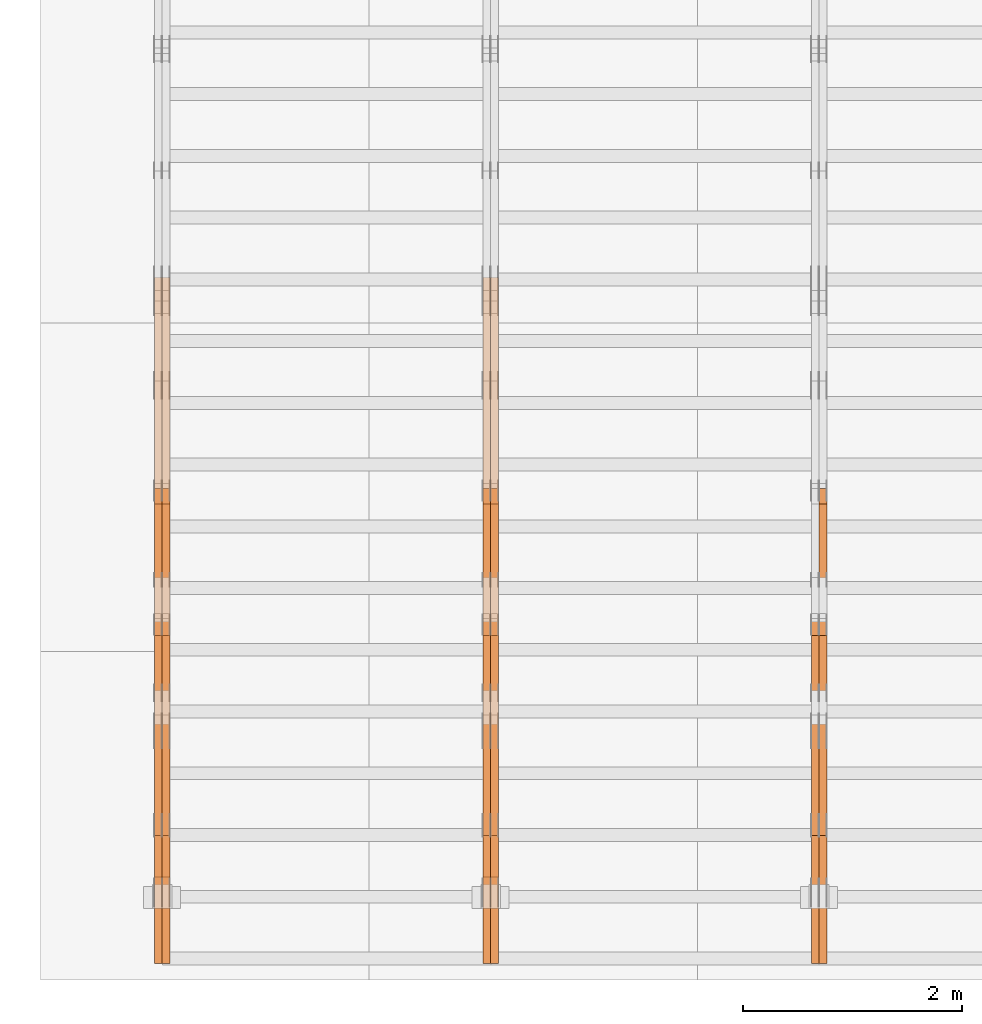
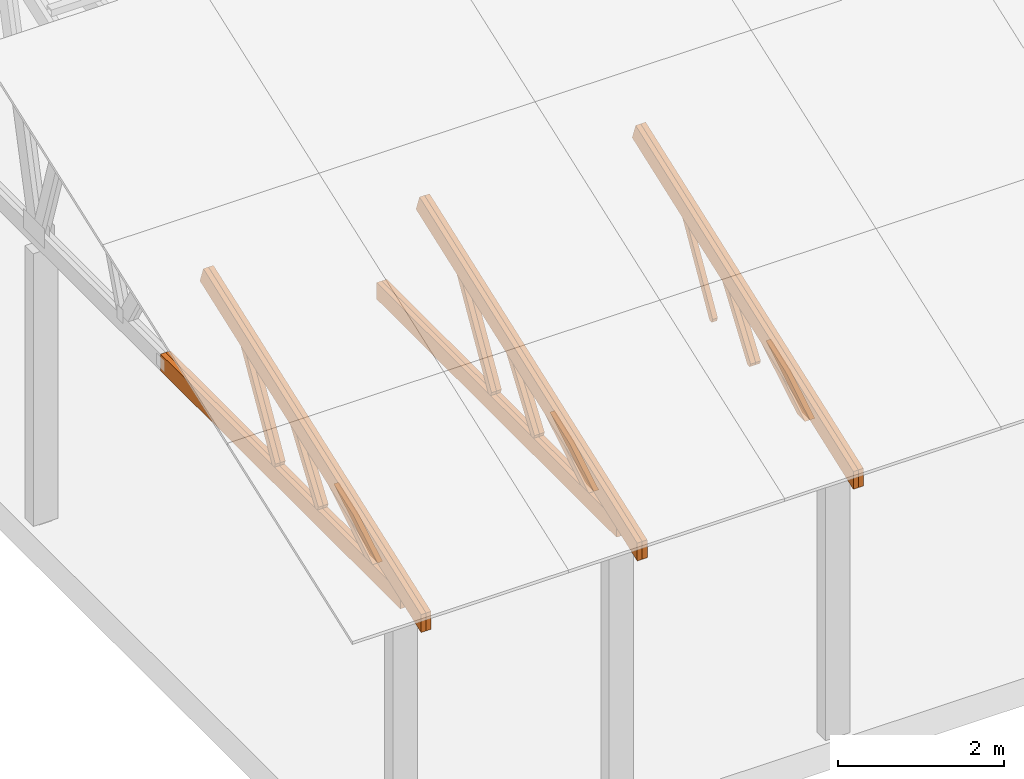
# One storey, part 12 of 189: 27 proxies.
"""IFC2X3 building model written with IfcOpenShell, lengths in millimetres."""

from ifc_helpers import new_model, entity, si_unit, converted_unit, derived_unit, direction, frame, origin, place, context, subcontext, project, spatial, polyline, outline, extrude, source, transform, mapped, material, type_object, type_shapes, element, save


model = new_model("IFC2X3")

# Units and contexts
model_context = context("Model", 3, precision=0.01, world=origin(), true_north=direction((6.12303176911189e-17, 1.0)))
body_context = subcontext(model_context, "Body", "Model", "MODEL_VIEW")
ifc_project = project(units=[si_unit("LENGTHUNIT", "METRE", prefix="MILLI"), si_unit("AREAUNIT", "SQUARE_METRE"), si_unit("VOLUMEUNIT", "CUBIC_METRE"), converted_unit("PLANEANGLEUNIT", "DEGREE", entity("IfcRatioMeasure", 0.0174532925199433), si_unit("PLANEANGLEUNIT", "RADIAN"), dimensions=[0, 0, 0, 0, 0, 0, 0]), si_unit("MASSUNIT", "GRAM", prefix="KILO"), derived_unit("MASSDENSITYUNIT", [(si_unit("MASSUNIT", "GRAM", prefix="KILO"), 1), (si_unit("LENGTHUNIT", "METRE"), -3)]), si_unit("TIMEUNIT", "SECOND"), si_unit("FREQUENCYUNIT", "HERTZ"), si_unit("THERMODYNAMICTEMPERATUREUNIT", "DEGREE_CELSIUS"), derived_unit("THERMALTRANSMITTANCEUNIT", [(si_unit("MASSUNIT", "GRAM", prefix="KILO"), 1), (si_unit("THERMODYNAMICTEMPERATUREUNIT", "KELVIN"), -1), (si_unit("TIMEUNIT", "SECOND"), -3)]), derived_unit("VOLUMETRICFLOWRATEUNIT", [(si_unit("LENGTHUNIT", "METRE"), 3), (si_unit("TIMEUNIT", "SECOND"), -1)]), si_unit("ELECTRICCURRENTUNIT", "AMPERE"), si_unit("ELECTRICVOLTAGEUNIT", "VOLT"), si_unit("POWERUNIT", "WATT"), si_unit("FORCEUNIT", "NEWTON"), si_unit("ILLUMINANCEUNIT", "LUX"), si_unit("LUMINOUSFLUXUNIT", "LUMEN"), si_unit("LUMINOUSINTENSITYUNIT", "CANDELA"), derived_unit("USERDEFINED", [(si_unit("MASSUNIT", "GRAM", prefix="KILO"), -1), (si_unit("LENGTHUNIT", "METRE"), -2), (si_unit("TIMEUNIT", "SECOND"), 3), (si_unit("LUMINOUSFLUXUNIT", "LUMEN"), 1)]), derived_unit("LINEARVELOCITYUNIT", [(si_unit("LENGTHUNIT", "METRE"), 1), (si_unit("TIMEUNIT", "SECOND"), -1)]), si_unit("PRESSUREUNIT", "PASCAL"), derived_unit("USERDEFINED", [(si_unit("LENGTHUNIT", "METRE"), -2), (si_unit("MASSUNIT", "GRAM", prefix="KILO"), 1), (si_unit("TIMEUNIT", "SECOND"), -2)])], contexts=[model_context])

# Site, building, storey
site_placement = place(None, origin())
site = spatial("IfcSite", under=ifc_project, at=site_placement, CompositionType="ELEMENT")
building_placement = place(site_placement, origin())
building = spatial("IfcBuilding", under=site, at=building_placement, CompositionType="ELEMENT")
storey_placement = place(building_placement, origin())
storey = spatial("IfcBuildingStorey", under=building, at=storey_placement, Name="Default", CompositionType="ELEMENT", Elevation=0.0)

# Proxies
ifc_material_1 = material(Name="IfcSurfaceStyle #34414")
building_element_proxy_type_1 = type_object("IfcBuildingElementProxyType", Name="T1-W11 34412", PredefinedType="NOTDEFINED", material=ifc_material_1)
shared_shape_1 = source(origin(), body_context, "Body", "SweptSolid", [
    extrude(outline(polyline([(593.358012843793, -552.565239103314), (742.388662259985, -552.565239103314), (-410.498749190676, 401.275038694583), (-462.246133468927, 382.44069706518), (-463.001792444175, 321.414742446865), (593.358012843793, -552.565239103314)])), frame((599.94412413079, 47.5003788877286, 0.0), z_axis=(0.0, 0.0, 1.0), x_axis=(0.770483455324544, 0.637459994879013, 0.0)), (0.0, 0.0, 1.0), 69.9999999999999),
])
type_shapes(building_element_proxy_type_1, [shared_shape_1])
proxy_1_placement = place(building_placement, frame((6335.0, 2983.26655629375, 269.034992751429), z_axis=(-1.0, 0.0, 0.0), x_axis=(0.0, 0.505995901100606, 0.862535882192379)))
element("IfcBuildingElementProxy", 1, at=proxy_1_placement, inside=storey, type_object=building_element_proxy_type_1, material=ifc_material_1, Name="T1-W11", context=body_context, shape_type="MappedRepresentation", body=[
    mapped(shared_shape_1, transform((0.0, 0.0, 0.0), scale=1.0)),
])
ifc_material_2 = material(Name="IfcSurfaceStyle #33886")
building_element_proxy_type_2 = type_object("IfcBuildingElementProxyType", Name="T1-W13 33884", PredefinedType="NOTDEFINED", material=ifc_material_2)
shared_shape_2 = source(origin(), body_context, "Body", "SweptSolid", [
    extrude(outline(polyline([(404.740440720218, -341.48092914206), (570.336320797765, -341.48092914206), (-287.911826743206, 259.650691447848), (-342.395697357435, 239.820346030744), (-344.769237417342, 183.490820805529), (404.740440720218, -341.48092914206)])), frame((418.029573061951, 47.5005675782689, 0.0), z_axis=(0.0, 0.0, 1.0), x_axis=(0.819070847746389, 0.573692379565924, 0.0)), (0.0, 0.0, 1.0), 69.9999999999999),
])
type_shapes(building_element_proxy_type_2, [shared_shape_2])
proxy_2_placement = place(building_placement, frame((6335.0, 1951.16403402681, 272.239720286334), z_axis=(-1.0, 0.0, 0.0), x_axis=(0.0, 0.573462629043499, 0.819231721242848)))
element("IfcBuildingElementProxy", 2, at=proxy_2_placement, inside=storey, type_object=building_element_proxy_type_2, material=ifc_material_2, Name="T1-W13", context=body_context, shape_type="MappedRepresentation", body=[
    mapped(shared_shape_2, transform((0.0, 0.0, 0.0), scale=1.0)),
])
ifc_material_3 = material(Name="IfcSurfaceStyle #33820")
building_element_proxy_type_3 = type_object("IfcBuildingElementProxyType", Name="T1-W13 33818", PredefinedType="NOTDEFINED", material=ifc_material_3)
shared_shape_3 = source(origin(), body_context, "Body", "SweptSolid", [
    extrude(outline(polyline([(404.740440720218, -341.48092914206), (570.336320797765, -341.48092914206), (-287.911826743206, 259.650691447848), (-342.395697357435, 239.820346030744), (-344.769237417342, 183.490820805529), (404.740440720218, -341.48092914206)])), frame((418.029573061951, 47.5005675782689, 0.0), z_axis=(0.0, 0.0, 1.0), x_axis=(0.819070847746389, 0.573692379565924, 0.0)), (0.0, 0.0, 1.0), 69.9999999999999),
])
type_shapes(building_element_proxy_type_3, [shared_shape_3])
proxy_3_placement = place(building_placement, frame((6265.0, 1951.16403402681, 272.239720286334), z_axis=(-1.0, 0.0, 0.0), x_axis=(0.0, 0.573462629043499, 0.819231721242848)))
element("IfcBuildingElementProxy", 3, at=proxy_3_placement, inside=storey, type_object=building_element_proxy_type_3, material=ifc_material_3, Name="T1-W13", context=body_context, shape_type="MappedRepresentation", body=[
    mapped(shared_shape_3, transform((0.0, 0.0, 0.0), scale=1.0)),
])
ifc_material_4 = material(Name="IfcSurfaceStyle #33358")
building_element_proxy_type_4 = type_object("IfcBuildingElementProxyType", Name="T1-W12 33356", PredefinedType="NOTDEFINED", material=ifc_material_4)
shared_shape_4 = source(origin(), body_context, "Body", "SweptSolid", [
    extrude(outline(polyline([(-671.888430889784, -47.499785620702), (344.892972119224, -47.499785620702), (503.856463083211, 47.4997856207019), (-176.861004312651, 47.499785620702), (-671.888430889784, -47.499785620702)])), frame((503.857114243549, 47.5002636410509, 0.0), z_axis=(0.0, 0.0, 1.0), x_axis=(-1.0, 0.0, 0.0)), (0.0, 0.0, 1.0), 69.9999999999999),
])
type_shapes(building_element_proxy_type_4, [shared_shape_4])
proxy_4_placement = place(building_placement, frame((6335.0, 665.58122707747, 245.000076287477), z_axis=(-1.0, 0.0, 0.0), x_axis=(0.0, 0.858392121304013, 0.51299411895576)))
element("IfcBuildingElementProxy", 4, at=proxy_4_placement, inside=storey, type_object=building_element_proxy_type_4, material=ifc_material_4, Name="T1-W12", context=body_context, shape_type="MappedRepresentation", body=[
    mapped(shared_shape_4, transform((0.0, 0.0, 0.0), scale=1.0)),
])
ifc_material_5 = material(Name="IfcSurfaceStyle #33301")
building_element_proxy_type_5 = type_object("IfcBuildingElementProxyType", Name="T1-W12 33299", PredefinedType="NOTDEFINED", material=ifc_material_5)
shared_shape_5 = source(origin(), body_context, "Body", "SweptSolid", [
    extrude(outline(polyline([(-671.888430889784, -47.499785620702), (344.892972119224, -47.499785620702), (503.856463083211, 47.4997856207019), (-176.861004312651, 47.499785620702), (-671.888430889784, -47.499785620702)])), frame((503.857114243549, 47.5002636410509, 0.0), z_axis=(0.0, 0.0, 1.0), x_axis=(-1.0, 0.0, 0.0)), (0.0, 0.0, 1.0), 69.9999999999999),
])
type_shapes(building_element_proxy_type_5, [shared_shape_5])
proxy_5_placement = place(building_placement, frame((6265.0, 665.58122707747, 245.000076287477), z_axis=(-1.0, 0.0, 0.0), x_axis=(0.0, 0.858392121304013, 0.51299411895576)))
element("IfcBuildingElementProxy", 5, at=proxy_5_placement, inside=storey, type_object=building_element_proxy_type_5, material=ifc_material_5, Name="T1-W12", context=body_context, shape_type="MappedRepresentation", body=[
    mapped(shared_shape_5, transform((0.0, 0.0, 0.0), scale=1.0)),
])
ifc_material_6 = material(Name="IfcSurfaceStyle #32410")
building_element_proxy_type_6 = type_object("IfcBuildingElementProxyType", Name="T1-T2 32408", PredefinedType="NOTDEFINED", material=ifc_material_6)
shared_shape_6 = source(origin(), body_context, "Body", "SweptSolid", [
    extrude(outline(polyline([(-2763.12044548193, -122.499971764318), (2807.70681121203, -122.499971764318), (2807.70678531127, 122.499971764318), (-2852.29315104137, 122.499971764318), (-2763.12044548193, -122.499971764318)])), frame((2807.70684902043, 122.500023191939, 0.0), z_axis=(0.0, 0.0, 1.0), x_axis=(-1.0, 0.0, 0.0)), (0.0, 0.0, 1.0), 69.9999999999997),
])
type_shapes(building_element_proxy_type_6, [shared_shape_6])
proxy_6_placement = place(building_placement, frame((6335.0, 4818.66023370631, 1893.1253396746), z_axis=(-1.0, 0.0, 0.0), x_axis=(0.0, -0.939692620785908, -0.342020143325669)))
element("IfcBuildingElementProxy", 6, at=proxy_6_placement, inside=storey, type_object=building_element_proxy_type_6, material=ifc_material_6, Name="T1-T2", context=body_context, shape_type="MappedRepresentation", body=[
    mapped(shared_shape_6, transform((0.0, 0.0, 0.0), scale=1.0)),
])
ifc_material_7 = material(Name="IfcSurfaceStyle #32353")
building_element_proxy_type_7 = type_object("IfcBuildingElementProxyType", Name="T1-T2 32351", PredefinedType="NOTDEFINED", material=ifc_material_7)
shared_shape_7 = source(origin(), body_context, "Body", "SweptSolid", [
    extrude(outline(polyline([(-2763.12044548193, -122.499971764318), (2807.70681121203, -122.499971764318), (2807.70678531127, 122.499971764318), (-2852.29315104137, 122.499971764318), (-2763.12044548193, -122.499971764318)])), frame((2807.70684902043, 122.500023191939, 0.0), z_axis=(0.0, 0.0, 1.0), x_axis=(-1.0, 0.0, 0.0)), (0.0, 0.0, 1.0), 69.9999999999997),
])
type_shapes(building_element_proxy_type_7, [shared_shape_7])
proxy_7_placement = place(building_placement, frame((6265.0, 4818.66023370631, 1893.1253396746), z_axis=(-1.0, 0.0, 0.0), x_axis=(0.0, -0.939692620785908, -0.342020143325669)))
element("IfcBuildingElementProxy", 7, at=proxy_7_placement, inside=storey, type_object=building_element_proxy_type_7, material=ifc_material_7, Name="T1-T2", context=body_context, shape_type="MappedRepresentation", body=[
    mapped(shared_shape_7, transform((0.0, 0.0, 0.0), scale=1.0)),
])
ifc_material_8 = material(Name="IfcSurfaceStyle #18624")
building_element_proxy_type_8 = type_object("IfcBuildingElementProxyType", Name="T1-W11 18622", PredefinedType="NOTDEFINED", material=ifc_material_8)
shared_shape_8 = source(origin(), body_context, "Body", "SweptSolid", [
    extrude(outline(polyline([(593.358012843793, -552.565239103314), (742.388662259985, -552.565239103314), (-410.498749190676, 401.275038694583), (-462.246133468927, 382.44069706518), (-463.001792444175, 321.414742446865), (593.358012843793, -552.565239103314)])), frame((599.94412413079, 47.5003788877286, 0.0), z_axis=(0.0, 0.0, 1.0), x_axis=(0.770483455324544, 0.637459994879013, 0.0)), (0.0, 0.0, 1.0), 69.9999999999999),
])
type_shapes(building_element_proxy_type_8, [shared_shape_8])
proxy_8_placement = place(building_placement, frame((3335.0, 2983.26655629375, 269.034992751429), z_axis=(-1.0, 0.0, 0.0), x_axis=(0.0, 0.505995901100606, 0.862535882192379)))
element("IfcBuildingElementProxy", 8, at=proxy_8_placement, inside=storey, type_object=building_element_proxy_type_8, material=ifc_material_8, Name="T1-W11", context=body_context, shape_type="MappedRepresentation", body=[
    mapped(shared_shape_8, transform((0.0, 0.0, 0.0), scale=1.0)),
])
ifc_material_9 = material(Name="IfcSurfaceStyle #18558")
building_element_proxy_type_9 = type_object("IfcBuildingElementProxyType", Name="T1-W11 18556", PredefinedType="NOTDEFINED", material=ifc_material_9)
shared_shape_9 = source(origin(), body_context, "Body", "SweptSolid", [
    extrude(outline(polyline([(593.358012843793, -552.565239103314), (742.388662259985, -552.565239103314), (-410.498749190676, 401.275038694583), (-462.246133468927, 382.44069706518), (-463.001792444175, 321.414742446865), (593.358012843793, -552.565239103314)])), frame((599.94412413079, 47.5003788877286, 0.0), z_axis=(0.0, 0.0, 1.0), x_axis=(0.770483455324544, 0.637459994879013, 0.0)), (0.0, 0.0, 1.0), 69.9999999999999),
])
type_shapes(building_element_proxy_type_9, [shared_shape_9])
proxy_9_placement = place(building_placement, frame((3265.0, 2983.26655629375, 269.034992751429), z_axis=(-1.0, 0.0, 0.0), x_axis=(0.0, 0.505995901100606, 0.862535882192379)))
element("IfcBuildingElementProxy", 9, at=proxy_9_placement, inside=storey, type_object=building_element_proxy_type_9, material=ifc_material_9, Name="T1-W11", context=body_context, shape_type="MappedRepresentation", body=[
    mapped(shared_shape_9, transform((0.0, 0.0, 0.0), scale=1.0)),
])
ifc_material_10 = material(Name="IfcSurfaceStyle #18096")
building_element_proxy_type_10 = type_object("IfcBuildingElementProxyType", Name="T1-W13 18094", PredefinedType="NOTDEFINED", material=ifc_material_10)
shared_shape_10 = source(origin(), body_context, "Body", "SweptSolid", [
    extrude(outline(polyline([(404.740440720218, -341.48092914206), (570.336320797765, -341.48092914206), (-287.911826743206, 259.650691447848), (-342.395697357435, 239.820346030744), (-344.769237417342, 183.490820805529), (404.740440720218, -341.48092914206)])), frame((418.029573061951, 47.5005675782689, 0.0), z_axis=(0.0, 0.0, 1.0), x_axis=(0.819070847746389, 0.573692379565924, 0.0)), (0.0, 0.0, 1.0), 69.9999999999999),
])
type_shapes(building_element_proxy_type_10, [shared_shape_10])
proxy_10_placement = place(building_placement, frame((3335.0, 1951.16403402681, 272.239720286334), z_axis=(-1.0, 0.0, 0.0), x_axis=(0.0, 0.573462629043499, 0.819231721242848)))
element("IfcBuildingElementProxy", 10, at=proxy_10_placement, inside=storey, type_object=building_element_proxy_type_10, material=ifc_material_10, Name="T1-W13", context=body_context, shape_type="MappedRepresentation", body=[
    mapped(shared_shape_10, transform((0.0, 0.0, 0.0), scale=1.0)),
])
ifc_material_11 = material(Name="IfcSurfaceStyle #18030")
building_element_proxy_type_11 = type_object("IfcBuildingElementProxyType", Name="T1-W13 18028", PredefinedType="NOTDEFINED", material=ifc_material_11)
shared_shape_11 = source(origin(), body_context, "Body", "SweptSolid", [
    extrude(outline(polyline([(404.740440720218, -341.48092914206), (570.336320797765, -341.48092914206), (-287.911826743206, 259.650691447848), (-342.395697357435, 239.820346030744), (-344.769237417342, 183.490820805529), (404.740440720218, -341.48092914206)])), frame((418.029573061951, 47.5005675782689, 0.0), z_axis=(0.0, 0.0, 1.0), x_axis=(0.819070847746389, 0.573692379565924, 0.0)), (0.0, 0.0, 1.0), 69.9999999999999),
])
type_shapes(building_element_proxy_type_11, [shared_shape_11])
proxy_11_placement = place(building_placement, frame((3265.0, 1951.16403402681, 272.239720286334), z_axis=(-1.0, 0.0, 0.0), x_axis=(0.0, 0.573462629043499, 0.819231721242848)))
element("IfcBuildingElementProxy", 11, at=proxy_11_placement, inside=storey, type_object=building_element_proxy_type_11, material=ifc_material_11, Name="T1-W13", context=body_context, shape_type="MappedRepresentation", body=[
    mapped(shared_shape_11, transform((0.0, 0.0, 0.0), scale=1.0)),
])
ifc_material_12 = material(Name="IfcSurfaceStyle #17568")
building_element_proxy_type_12 = type_object("IfcBuildingElementProxyType", Name="T1-W12 17566", PredefinedType="NOTDEFINED", material=ifc_material_12)
shared_shape_12 = source(origin(), body_context, "Body", "SweptSolid", [
    extrude(outline(polyline([(-671.888430889784, -47.499785620702), (344.892972119224, -47.499785620702), (503.856463083211, 47.4997856207019), (-176.861004312651, 47.499785620702), (-671.888430889784, -47.499785620702)])), frame((503.857114243549, 47.5002636410509, 0.0), z_axis=(0.0, 0.0, 1.0), x_axis=(-1.0, 0.0, 0.0)), (0.0, 0.0, 1.0), 69.9999999999999),
])
type_shapes(building_element_proxy_type_12, [shared_shape_12])
proxy_12_placement = place(building_placement, frame((3335.0, 665.58122707747, 245.000076287477), z_axis=(-1.0, 0.0, 0.0), x_axis=(0.0, 0.858392121304013, 0.51299411895576)))
element("IfcBuildingElementProxy", 12, at=proxy_12_placement, inside=storey, type_object=building_element_proxy_type_12, material=ifc_material_12, Name="T1-W12", context=body_context, shape_type="MappedRepresentation", body=[
    mapped(shared_shape_12, transform((0.0, 0.0, 0.0), scale=1.0)),
])
ifc_material_13 = material(Name="IfcSurfaceStyle #17511")
building_element_proxy_type_13 = type_object("IfcBuildingElementProxyType", Name="T1-W12 17509", PredefinedType="NOTDEFINED", material=ifc_material_13)
shared_shape_13 = source(origin(), body_context, "Body", "SweptSolid", [
    extrude(outline(polyline([(-671.888430889784, -47.499785620702), (344.892972119224, -47.499785620702), (503.856463083211, 47.4997856207019), (-176.861004312651, 47.499785620702), (-671.888430889784, -47.499785620702)])), frame((503.857114243549, 47.5002636410509, 0.0), z_axis=(0.0, 0.0, 1.0), x_axis=(-1.0, 0.0, 0.0)), (0.0, 0.0, 1.0), 69.9999999999999),
])
type_shapes(building_element_proxy_type_13, [shared_shape_13])
proxy_13_placement = place(building_placement, frame((3265.0, 665.58122707747, 245.000076287477), z_axis=(-1.0, 0.0, 0.0), x_axis=(0.0, 0.858392121304013, 0.51299411895576)))
element("IfcBuildingElementProxy", 13, at=proxy_13_placement, inside=storey, type_object=building_element_proxy_type_13, material=ifc_material_13, Name="T1-W12", context=body_context, shape_type="MappedRepresentation", body=[
    mapped(shared_shape_13, transform((0.0, 0.0, 0.0), scale=1.0)),
])
ifc_material_14 = material(Name="IfcSurfaceStyle #16752")
building_element_proxy_type_14 = type_object("IfcBuildingElementProxyType", Name="T1-B2 16750", PredefinedType="NOTDEFINED", material=ifc_material_14)
shared_shape_14 = source(origin(), body_context, "Body", "SweptSolid", [
    extrude(outline(polyline([(-3399.385546875, -125.855288696291), (2363.08125, -125.855288696291), (2363.08125, 13.4211547851572), (2072.60859375, 119.144711303712), (-3399.385546875, 119.144711303712), (-3399.385546875, -125.855288696291)])), frame((2363.08125, 119.144711303712, 0.0), z_axis=(0.0, 0.0, 1.0), x_axis=(-1.0, 0.0, 0.0)), (0.0, 0.0, 1.0), 69.9999999999997),
])
type_shapes(building_element_proxy_type_14, [shared_shape_14])
proxy_14_placement = place(building_placement, frame((3335.0, 0.0, 245.0), z_axis=(-1.0, 0.0, 0.0), x_axis=(0.0, 1.0, 0.0)))
element("IfcBuildingElementProxy", 14, at=proxy_14_placement, inside=storey, type_object=building_element_proxy_type_14, material=ifc_material_14, Name="T1-B2", context=body_context, shape_type="MappedRepresentation", body=[
    mapped(shared_shape_14, transform((0.0, 0.0, 0.0), scale=1.0)),
])
ifc_material_15 = material(Name="IfcSurfaceStyle #16686")
building_element_proxy_type_15 = type_object("IfcBuildingElementProxyType", Name="T1-B2 16684", PredefinedType="NOTDEFINED", material=ifc_material_15)
shared_shape_15 = source(origin(), body_context, "Body", "SweptSolid", [
    extrude(outline(polyline([(-3399.385546875, -125.855288696291), (2363.08125, -125.855288696291), (2363.08125, 13.4211547851572), (2072.60859375, 119.144711303712), (-3399.385546875, 119.144711303712), (-3399.385546875, -125.855288696291)])), frame((2363.08125, 119.144711303712, 0.0), z_axis=(0.0, 0.0, 1.0), x_axis=(-1.0, 0.0, 0.0)), (0.0, 0.0, 1.0), 69.9999999999997),
])
type_shapes(building_element_proxy_type_15, [shared_shape_15])
proxy_15_placement = place(building_placement, frame((3265.0, 0.0, 245.0), z_axis=(-1.0, 0.0, 0.0), x_axis=(0.0, 1.0, 0.0)))
element("IfcBuildingElementProxy", 15, at=proxy_15_placement, inside=storey, type_object=building_element_proxy_type_15, material=ifc_material_15, Name="T1-B2", context=body_context, shape_type="MappedRepresentation", body=[
    mapped(shared_shape_15, transform((0.0, 0.0, 0.0), scale=1.0)),
])
ifc_material_16 = material(Name="IfcSurfaceStyle #16620")
building_element_proxy_type_16 = type_object("IfcBuildingElementProxyType", Name="T1-T2 16618", PredefinedType="NOTDEFINED", material=ifc_material_16)
shared_shape_16 = source(origin(), body_context, "Body", "SweptSolid", [
    extrude(outline(polyline([(-2763.12044548193, -122.499971764318), (2807.70681121203, -122.499971764318), (2807.70678531127, 122.499971764318), (-2852.29315104137, 122.499971764318), (-2763.12044548193, -122.499971764318)])), frame((2807.70684902043, 122.500023191939, 0.0), z_axis=(0.0, 0.0, 1.0), x_axis=(-1.0, 0.0, 0.0)), (0.0, 0.0, 1.0), 69.9999999999997),
])
type_shapes(building_element_proxy_type_16, [shared_shape_16])
proxy_16_placement = place(building_placement, frame((3335.0, 4818.66023370631, 1893.1253396746), z_axis=(-1.0, 0.0, 0.0), x_axis=(0.0, -0.939692620785908, -0.342020143325669)))
element("IfcBuildingElementProxy", 16, at=proxy_16_placement, inside=storey, type_object=building_element_proxy_type_16, material=ifc_material_16, Name="T1-T2", context=body_context, shape_type="MappedRepresentation", body=[
    mapped(shared_shape_16, transform((0.0, 0.0, 0.0), scale=1.0)),
])
ifc_material_17 = material(Name="IfcSurfaceStyle #16563")
building_element_proxy_type_17 = type_object("IfcBuildingElementProxyType", Name="T1-T2 16561", PredefinedType="NOTDEFINED", material=ifc_material_17)
shared_shape_17 = source(origin(), body_context, "Body", "SweptSolid", [
    extrude(outline(polyline([(-2763.12044548193, -122.499971764318), (2807.70681121203, -122.499971764318), (2807.70678531127, 122.499971764318), (-2852.29315104137, 122.499971764318), (-2763.12044548193, -122.499971764318)])), frame((2807.70684902043, 122.500023191939, 0.0), z_axis=(0.0, 0.0, 1.0), x_axis=(-1.0, 0.0, 0.0)), (0.0, 0.0, 1.0), 69.9999999999997),
])
type_shapes(building_element_proxy_type_17, [shared_shape_17])
proxy_17_placement = place(building_placement, frame((3265.0, 4818.66023370631, 1893.1253396746), z_axis=(-1.0, 0.0, 0.0), x_axis=(0.0, -0.939692620785908, -0.342020143325669)))
element("IfcBuildingElementProxy", 17, at=proxy_17_placement, inside=storey, type_object=building_element_proxy_type_17, material=ifc_material_17, Name="T1-T2", context=body_context, shape_type="MappedRepresentation", body=[
    mapped(shared_shape_17, transform((0.0, 0.0, 0.0), scale=1.0)),
])
ifc_material_18 = material(Name="IfcSurfaceStyle #2831")
building_element_proxy_type_18 = type_object("IfcBuildingElementProxyType", Name="T1-W11 2829", PredefinedType="NOTDEFINED", material=ifc_material_18)
shared_shape_18 = source(origin(), body_context, "Body", "SweptSolid", [
    extrude(outline(polyline([(593.358012843793, -552.565239103314), (742.388662259985, -552.565239103314), (-410.498749190676, 401.275038694583), (-462.246133468927, 382.44069706518), (-463.001792444175, 321.414742446865), (593.358012843793, -552.565239103314)])), frame((599.94412413079, 47.5003788877286, 0.0), z_axis=(0.0, 0.0, 1.0), x_axis=(0.770483455324544, 0.637459994879013, 0.0)), (0.0, 0.0, 1.0), 69.9999999999999),
])
type_shapes(building_element_proxy_type_18, [shared_shape_18])
proxy_18_placement = place(building_placement, frame((335.0, 2983.26655629375, 269.034992751429), z_axis=(-1.0, 0.0, 0.0), x_axis=(0.0, 0.505995901100606, 0.862535882192379)))
element("IfcBuildingElementProxy", 18, at=proxy_18_placement, inside=storey, type_object=building_element_proxy_type_18, material=ifc_material_18, Name="T1-W11", context=body_context, shape_type="MappedRepresentation", body=[
    mapped(shared_shape_18, transform((0.0, 0.0, 0.0), scale=1.0)),
])
ifc_material_19 = material(Name="IfcSurfaceStyle #2765")
building_element_proxy_type_19 = type_object("IfcBuildingElementProxyType", Name="T1-W11 2763", PredefinedType="NOTDEFINED", material=ifc_material_19)
shared_shape_19 = source(origin(), body_context, "Body", "SweptSolid", [
    extrude(outline(polyline([(593.358012843793, -552.565239103314), (742.388662259985, -552.565239103314), (-410.498749190676, 401.275038694583), (-462.246133468927, 382.44069706518), (-463.001792444175, 321.414742446865), (593.358012843793, -552.565239103314)])), frame((599.94412413079, 47.5003788877286, 0.0), z_axis=(0.0, 0.0, 1.0), x_axis=(0.770483455324544, 0.637459994879013, 0.0)), (0.0, 0.0, 1.0), 69.9999999999999),
])
type_shapes(building_element_proxy_type_19, [shared_shape_19])
proxy_19_placement = place(building_placement, frame((265.0, 2983.26655629375, 269.034992751429), z_axis=(-1.0, 0.0, 0.0), x_axis=(0.0, 0.505995901100606, 0.862535882192379)))
element("IfcBuildingElementProxy", 19, at=proxy_19_placement, inside=storey, type_object=building_element_proxy_type_19, material=ifc_material_19, Name="T1-W11", context=body_context, shape_type="MappedRepresentation", body=[
    mapped(shared_shape_19, transform((0.0, 0.0, 0.0), scale=1.0)),
])
ifc_material_20 = material(Name="IfcSurfaceStyle #2303")
building_element_proxy_type_20 = type_object("IfcBuildingElementProxyType", Name="T1-W13 2301", PredefinedType="NOTDEFINED", material=ifc_material_20)
shared_shape_20 = source(origin(), body_context, "Body", "SweptSolid", [
    extrude(outline(polyline([(404.740440720218, -341.48092914206), (570.336320797765, -341.48092914206), (-287.911826743206, 259.650691447848), (-342.395697357435, 239.820346030744), (-344.769237417342, 183.490820805529), (404.740440720218, -341.48092914206)])), frame((418.029573061951, 47.5005675782689, 0.0), z_axis=(0.0, 0.0, 1.0), x_axis=(0.819070847746389, 0.573692379565924, 0.0)), (0.0, 0.0, 1.0), 69.9999999999999),
])
type_shapes(building_element_proxy_type_20, [shared_shape_20])
proxy_20_placement = place(building_placement, frame((335.0, 1951.16403402681, 272.239720286334), z_axis=(-1.0, 0.0, 0.0), x_axis=(0.0, 0.573462629043499, 0.819231721242848)))
element("IfcBuildingElementProxy", 20, at=proxy_20_placement, inside=storey, type_object=building_element_proxy_type_20, material=ifc_material_20, Name="T1-W13", context=body_context, shape_type="MappedRepresentation", body=[
    mapped(shared_shape_20, transform((0.0, 0.0, 0.0), scale=1.0)),
])
ifc_material_21 = material(Name="IfcSurfaceStyle #2237")
building_element_proxy_type_21 = type_object("IfcBuildingElementProxyType", Name="T1-W13 2235", PredefinedType="NOTDEFINED", material=ifc_material_21)
shared_shape_21 = source(origin(), body_context, "Body", "SweptSolid", [
    extrude(outline(polyline([(404.740440720218, -341.48092914206), (570.336320797765, -341.48092914206), (-287.911826743206, 259.650691447848), (-342.395697357435, 239.820346030744), (-344.769237417342, 183.490820805529), (404.740440720218, -341.48092914206)])), frame((418.029573061951, 47.5005675782689, 0.0), z_axis=(0.0, 0.0, 1.0), x_axis=(0.819070847746389, 0.573692379565924, 0.0)), (0.0, 0.0, 1.0), 69.9999999999999),
])
type_shapes(building_element_proxy_type_21, [shared_shape_21])
proxy_21_placement = place(building_placement, frame((265.0, 1951.16403402681, 272.239720286334), z_axis=(-1.0, 0.0, 0.0), x_axis=(0.0, 0.573462629043499, 0.819231721242848)))
element("IfcBuildingElementProxy", 21, at=proxy_21_placement, inside=storey, type_object=building_element_proxy_type_21, material=ifc_material_21, Name="T1-W13", context=body_context, shape_type="MappedRepresentation", body=[
    mapped(shared_shape_21, transform((0.0, 0.0, 0.0), scale=1.0)),
])
ifc_material_22 = material(Name="IfcSurfaceStyle #1775")
building_element_proxy_type_22 = type_object("IfcBuildingElementProxyType", Name="T1-W12 1773", PredefinedType="NOTDEFINED", material=ifc_material_22)
shared_shape_22 = source(origin(), body_context, "Body", "SweptSolid", [
    extrude(outline(polyline([(-671.888430889784, -47.499785620702), (344.892972119224, -47.499785620702), (503.856463083211, 47.4997856207019), (-176.861004312651, 47.499785620702), (-671.888430889784, -47.499785620702)])), frame((503.857114243549, 47.5002636410509, 0.0), z_axis=(0.0, 0.0, 1.0), x_axis=(-1.0, 0.0, 0.0)), (0.0, 0.0, 1.0), 69.9999999999999),
])
type_shapes(building_element_proxy_type_22, [shared_shape_22])
proxy_22_placement = place(building_placement, frame((335.0, 665.58122707747, 245.000076287477), z_axis=(-1.0, 0.0, 0.0), x_axis=(0.0, 0.858392121304013, 0.51299411895576)))
element("IfcBuildingElementProxy", 22, at=proxy_22_placement, inside=storey, type_object=building_element_proxy_type_22, material=ifc_material_22, Name="T1-W12", context=body_context, shape_type="MappedRepresentation", body=[
    mapped(shared_shape_22, transform((0.0, 0.0, 0.0), scale=1.0)),
])
ifc_material_23 = material(Name="IfcSurfaceStyle #1718")
building_element_proxy_type_23 = type_object("IfcBuildingElementProxyType", Name="T1-W12 1716", PredefinedType="NOTDEFINED", material=ifc_material_23)
shared_shape_23 = source(origin(), body_context, "Body", "SweptSolid", [
    extrude(outline(polyline([(-671.888430889784, -47.499785620702), (344.892972119224, -47.499785620702), (503.856463083211, 47.4997856207019), (-176.861004312651, 47.499785620702), (-671.888430889784, -47.499785620702)])), frame((503.857114243549, 47.5002636410509, 0.0), z_axis=(0.0, 0.0, 1.0), x_axis=(-1.0, 0.0, 0.0)), (0.0, 0.0, 1.0), 69.9999999999999),
])
type_shapes(building_element_proxy_type_23, [shared_shape_23])
proxy_23_placement = place(building_placement, frame((265.0, 665.58122707747, 245.000076287477), z_axis=(-1.0, 0.0, 0.0), x_axis=(0.0, 0.858392121304013, 0.51299411895576)))
element("IfcBuildingElementProxy", 23, at=proxy_23_placement, inside=storey, type_object=building_element_proxy_type_23, material=ifc_material_23, Name="T1-W12", context=body_context, shape_type="MappedRepresentation", body=[
    mapped(shared_shape_23, transform((0.0, 0.0, 0.0), scale=1.0)),
])
ifc_material_24 = material(Name="IfcSurfaceStyle #959")
building_element_proxy_type_24 = type_object("IfcBuildingElementProxyType", Name="T1-B2 957", PredefinedType="NOTDEFINED", material=ifc_material_24)
shared_shape_24 = source(origin(), body_context, "Body", "SweptSolid", [
    extrude(outline(polyline([(-3399.385546875, -125.855288696291), (2363.08125, -125.855288696291), (2363.08125, 13.4211547851572), (2072.60859375, 119.144711303712), (-3399.385546875, 119.144711303712), (-3399.385546875, -125.855288696291)])), frame((2363.08125, 119.144711303712, 0.0), z_axis=(0.0, 0.0, 1.0), x_axis=(-1.0, 0.0, 0.0)), (0.0, 0.0, 1.0), 69.9999999999997),
])
type_shapes(building_element_proxy_type_24, [shared_shape_24])
proxy_24_placement = place(building_placement, frame((335.0, 0.0, 245.0), z_axis=(-1.0, 0.0, 0.0), x_axis=(0.0, 1.0, 0.0)))
element("IfcBuildingElementProxy", 24, at=proxy_24_placement, inside=storey, type_object=building_element_proxy_type_24, material=ifc_material_24, Name="T1-B2", context=body_context, shape_type="MappedRepresentation", body=[
    mapped(shared_shape_24, transform((0.0, 0.0, 0.0), scale=1.0)),
])
ifc_material_25 = material(Name="IfcSurfaceStyle #893")
building_element_proxy_type_25 = type_object("IfcBuildingElementProxyType", Name="T1-B2 891", PredefinedType="NOTDEFINED", material=ifc_material_25)
shared_shape_25 = source(origin(), body_context, "Body", "SweptSolid", [
    extrude(outline(polyline([(-3399.385546875, -125.855288696291), (2363.08125, -125.855288696291), (2363.08125, 13.4211547851572), (2072.60859375, 119.144711303712), (-3399.385546875, 119.144711303712), (-3399.385546875, -125.855288696291)])), frame((2363.08125, 119.144711303712, 0.0), z_axis=(0.0, 0.0, 1.0), x_axis=(-1.0, 0.0, 0.0)), (0.0, 0.0, 1.0), 69.9999999999997),
])
type_shapes(building_element_proxy_type_25, [shared_shape_25])
proxy_25_placement = place(building_placement, frame((265.0, 0.0, 245.0), z_axis=(-1.0, 0.0, 0.0), x_axis=(0.0, 1.0, 0.0)))
element("IfcBuildingElementProxy", 25, at=proxy_25_placement, inside=storey, type_object=building_element_proxy_type_25, material=ifc_material_25, Name="T1-B2", context=body_context, shape_type="MappedRepresentation", body=[
    mapped(shared_shape_25, transform((0.0, 0.0, 0.0), scale=1.0)),
])
ifc_material_26 = material(Name="IfcSurfaceStyle #827")
building_element_proxy_type_26 = type_object("IfcBuildingElementProxyType", Name="T1-T2 825", PredefinedType="NOTDEFINED", material=ifc_material_26)
shared_shape_26 = source(origin(), body_context, "Body", "SweptSolid", [
    extrude(outline(polyline([(-2763.12044548193, -122.499971764318), (2807.70681121203, -122.499971764318), (2807.70678531127, 122.499971764318), (-2852.29315104137, 122.499971764318), (-2763.12044548193, -122.499971764318)])), frame((2807.70684902043, 122.500023191939, 0.0), z_axis=(0.0, 0.0, 1.0), x_axis=(-1.0, 0.0, 0.0)), (0.0, 0.0, 1.0), 69.9999999999997),
])
type_shapes(building_element_proxy_type_26, [shared_shape_26])
proxy_26_placement = place(building_placement, frame((335.0, 4818.66023370631, 1893.1253396746), z_axis=(-1.0, 0.0, 0.0), x_axis=(0.0, -0.939692620785908, -0.342020143325669)))
element("IfcBuildingElementProxy", 26, at=proxy_26_placement, inside=storey, type_object=building_element_proxy_type_26, material=ifc_material_26, Name="T1-T2", context=body_context, shape_type="MappedRepresentation", body=[
    mapped(shared_shape_26, transform((0.0, 0.0, 0.0), scale=1.0)),
])
ifc_material_27 = material(Name="IfcSurfaceStyle #770")
building_element_proxy_type_27 = type_object("IfcBuildingElementProxyType", Name="T1-T2 768", PredefinedType="NOTDEFINED", material=ifc_material_27)
shared_shape_27 = source(origin(), body_context, "Body", "SweptSolid", [
    extrude(outline(polyline([(-2763.12044548193, -122.499971764318), (2807.70681121203, -122.499971764318), (2807.70678531127, 122.499971764318), (-2852.29315104137, 122.499971764318), (-2763.12044548193, -122.499971764318)])), frame((2807.70684902043, 122.500023191939, 0.0), z_axis=(0.0, 0.0, 1.0), x_axis=(-1.0, 0.0, 0.0)), (0.0, 0.0, 1.0), 69.9999999999997),
])
type_shapes(building_element_proxy_type_27, [shared_shape_27])
proxy_27_placement = place(building_placement, frame((265.0, 4818.66023370631, 1893.1253396746), z_axis=(-1.0, 0.0, 0.0), x_axis=(0.0, -0.939692620785908, -0.342020143325669)))
element("IfcBuildingElementProxy", 27, at=proxy_27_placement, inside=storey, type_object=building_element_proxy_type_27, material=ifc_material_27, Name="T1-T2", context=body_context, shape_type="MappedRepresentation", body=[
    mapped(shared_shape_27, transform((0.0, 0.0, 0.0), scale=1.0)),
])

save(model, "model.ifc")
